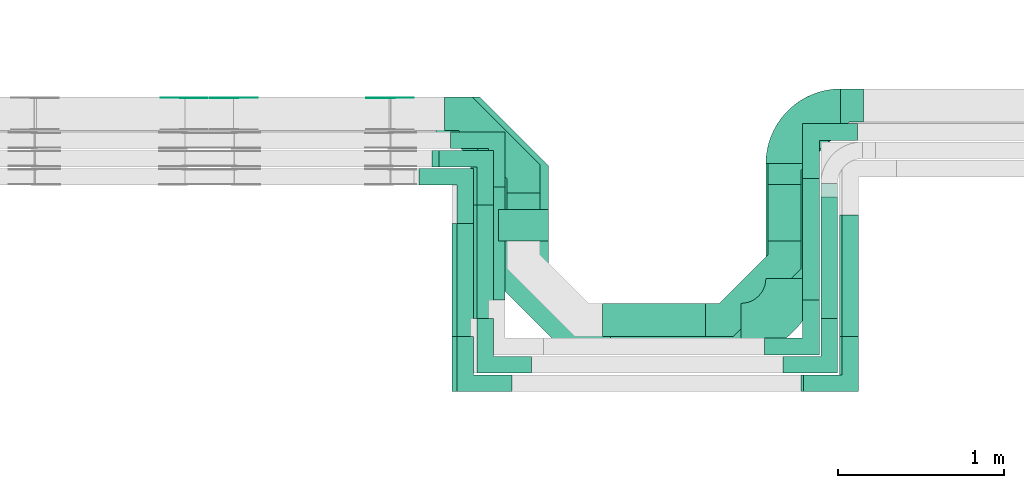
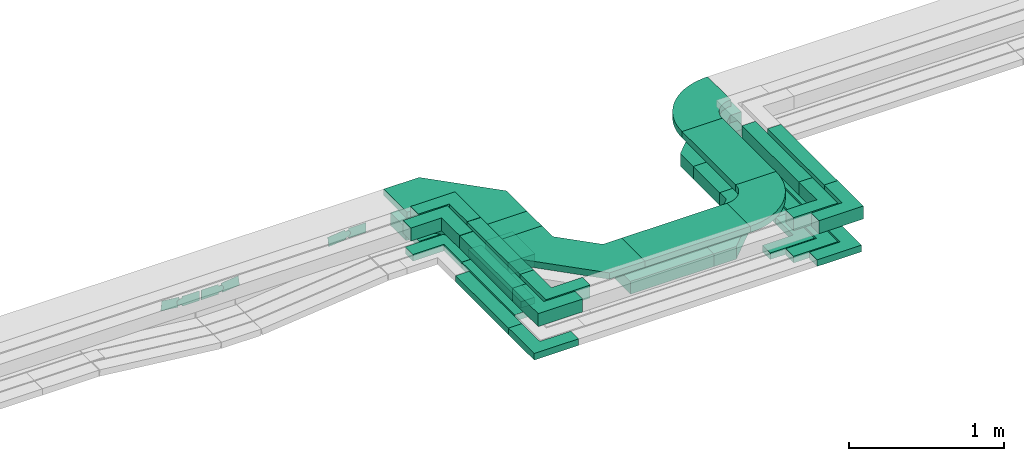
# One storey, part 20 of 33: 26 flow fittings, 16 flow segments.
"""IFC2X3 building model written with IfcOpenShell, lengths in millimetres."""

from ifc_helpers import new_model, entity, si_unit, converted_unit, derived_unit, direction, frame, frame_2d, origin, origin_2d_with_axis, place, context, subcontext, project, spatial, polyline, circle_curve, parameter, trimmed, segment, composite_curve, rectangle, outline, extrude, source, transform, mapped, material, type_object, type_shapes, element, save


model = new_model("IFC2X3")

# Units and contexts
model_context = context("Model", 3, precision=0.01, world=origin(), true_north=direction((6.12303176911189e-17, 1.0)))
body_context = subcontext(model_context, "Body", "Model", "MODEL_VIEW")
ifc_project = project(units=[si_unit("LENGTHUNIT", "METRE", prefix="MILLI"), si_unit("AREAUNIT", "SQUARE_METRE"), si_unit("VOLUMEUNIT", "CUBIC_METRE"), converted_unit("PLANEANGLEUNIT", "DEGREE", entity("IfcRatioMeasure", 0.0174532925199433), si_unit("PLANEANGLEUNIT", "RADIAN"), dimensions=[0, 0, 0, 0, 0, 0, 0]), si_unit("MASSUNIT", "GRAM", prefix="KILO"), derived_unit("MASSDENSITYUNIT", [(si_unit("MASSUNIT", "GRAM", prefix="KILO"), 1), (si_unit("LENGTHUNIT", "METRE"), -3)]), derived_unit("MOMENTOFINERTIAUNIT", [(si_unit("LENGTHUNIT", "METRE"), 4)]), si_unit("TIMEUNIT", "SECOND"), si_unit("FREQUENCYUNIT", "HERTZ"), si_unit("THERMODYNAMICTEMPERATUREUNIT", "DEGREE_CELSIUS"), derived_unit("THERMALTRANSMITTANCEUNIT", [(si_unit("MASSUNIT", "GRAM", prefix="KILO"), 1), (si_unit("THERMODYNAMICTEMPERATUREUNIT", "KELVIN"), -1), (si_unit("TIMEUNIT", "SECOND"), -3)]), derived_unit("VOLUMETRICFLOWRATEUNIT", [(si_unit("LENGTHUNIT", "METRE"), 3), (si_unit("TIMEUNIT", "SECOND"), -1)]), derived_unit("MASSFLOWRATEUNIT", [(si_unit("MASSUNIT", "GRAM", prefix="KILO"), 1), (si_unit("TIMEUNIT", "SECOND"), -1)]), derived_unit("ROTATIONALFREQUENCYUNIT", [(si_unit("TIMEUNIT", "SECOND"), -1)]), si_unit("ELECTRICCURRENTUNIT", "AMPERE"), si_unit("ELECTRICVOLTAGEUNIT", "VOLT"), si_unit("POWERUNIT", "WATT"), si_unit("FORCEUNIT", "NEWTON", prefix="KILO"), si_unit("ILLUMINANCEUNIT", "LUX"), si_unit("LUMINOUSFLUXUNIT", "LUMEN"), si_unit("LUMINOUSINTENSITYUNIT", "CANDELA"), derived_unit("USERDEFINED", [(si_unit("MASSUNIT", "GRAM", prefix="KILO"), -1), (si_unit("LENGTHUNIT", "METRE"), -2), (si_unit("TIMEUNIT", "SECOND"), 3), (si_unit("LUMINOUSFLUXUNIT", "LUMEN"), 1)]), derived_unit("LINEARVELOCITYUNIT", [(si_unit("LENGTHUNIT", "METRE"), 1), (si_unit("TIMEUNIT", "SECOND"), -1)]), si_unit("PRESSUREUNIT", "PASCAL"), derived_unit("USERDEFINED", [(si_unit("LENGTHUNIT", "METRE"), -2), (si_unit("MASSUNIT", "GRAM", prefix="KILO"), 1), (si_unit("TIMEUNIT", "SECOND"), -2)]), derived_unit("LINEARFORCEUNIT", [(si_unit("MASSUNIT", "GRAM", prefix="KILO"), 1), (si_unit("LENGTHUNIT", "METRE"), 1), (si_unit("TIMEUNIT", "SECOND"), -2), (si_unit("LENGTHUNIT", "METRE"), -1)]), derived_unit("PLANARFORCEUNIT", [(si_unit("MASSUNIT", "GRAM", prefix="KILO"), 1), (si_unit("LENGTHUNIT", "METRE"), 1), (si_unit("TIMEUNIT", "SECOND"), -2), (si_unit("LENGTHUNIT", "METRE"), -2)])], contexts=[model_context])

# Site, building, storey
site_placement = place(None, frame((0.0, -0.00077364408347762, 0.0)))
site = spatial("IfcSite", under=ifc_project, at=site_placement, CompositionType="ELEMENT")
building_placement = place(site_placement, origin())
building = spatial("IfcBuilding", under=site, at=building_placement, CompositionType="ELEMENT")
storey_placement = place(building_placement, frame((0.0, 0.0, 8100.0)))
storey = spatial("IfcBuildingStorey", under=building, at=storey_placement, CompositionType="ELEMENT", Elevation=8100.0)

# Flow segments
cable_carrier_segment_type = type_object("IfcCableCarrierSegmentType", PredefinedType="CABLETRAYSEGMENT")
flow_segment_1_placement = place(storey_placement, frame((42997.1884624457, 9308.68960275249, 2547.39498136109)))
element("IfcFlowSegment", 1, at=flow_segment_1_placement, inside=storey, type_object=cable_carrier_segment_type, context=body_context, shape_type="SweptSolid", body=[
    extrude(rectangle(XDim=290.308950714313, YDim=200.000000000007, at=frame_2d((-5.40012479177676e-13, 4.33431068813661e-12), x_axis=(1.0, 0.0))), frame((100.0, 145.154475357158, 0.0), z_axis=(0.0, 0.0, 1.0), x_axis=(0.0, -1.0, 0.0)), (0.0, 0.0, 1.0), 99.9999999999989),
])
flow_segment_2_placement = place(storey_placement, frame((42887.1884624458, 8952.68960275249, 2544.92549664435)))
element("IfcFlowSegment", 2, at=flow_segment_2_placement, inside=storey, type_object=cable_carrier_segment_type, context=body_context, shape_type="SweptSolid", body=[
    extrude(rectangle(XDim=682.308950714327, YDim=99.9999999999946, at=frame_2d((0.0, 4.33075797445781e-12), x_axis=(1.0, 0.0))), frame((50.0, 341.154475357164, 0.0), z_axis=(0.0, 0.0, 1.0), x_axis=(0.0, -1.0, 0.0)), (0.0, 0.0, 1.0), 50.0000000000016),
])
flow_segment_3_placement = place(storey_placement, frame((42777.1884624458, 8842.6896027525, 2546.31908538351)))
element("IfcFlowSegment", 3, at=flow_segment_3_placement, inside=storey, type_object=cable_carrier_segment_type, context=body_context, shape_type="SweptSolid", body=[
    extrude(rectangle(XDim=682.308950714317, YDim=99.9999999999946, at=frame_2d((0.0, 4.33075797445781e-12), x_axis=(1.0, 0.0))), frame((50.0, 341.154475357159, 0.0), z_axis=(0.0, 0.0, 1.0), x_axis=(0.0, -1.0, 0.0)), (0.0, 0.0, 1.0), 49.9999999999995),
])
flow_segment_4_placement = place(storey_placement, frame((42667.1884624458, 8732.69104941504, 2546.66940793271)))
element("IfcFlowSegment", 4, at=flow_segment_4_placement, inside=storey, type_object=cable_carrier_segment_type, context=body_context, shape_type="SweptSolid", body=[
    extrude(rectangle(XDim=682.307504051767, YDim=99.9999999999946, at=origin_2d_with_axis()), frame((50.0, 341.153752025884, 0.0), z_axis=(0.0, 0.0, 1.0), x_axis=(0.0, -1.0, 0.0)), (0.0, 0.0, 1.0), 50.0000000000016),
])
flow_segment_5_placement = place(storey_placement, frame((42697.1884624458, 8732.69104941503, 2799.2813532093)))
element("IfcFlowSegment", 5, at=flow_segment_5_placement, inside=storey, type_object=cable_carrier_segment_type, context=body_context, shape_type="SweptSolid", body=[
    extrude(rectangle(XDim=682.307504051765, YDim=99.9999999999946, at=frame_2d((-1.08002495835535e-12, 0.0), x_axis=(1.0, 0.0))), frame((50.0, 341.153752025881, 0.0), z_axis=(0.0, 0.0, 1.0), x_axis=(0.0, -1.0, 0.0)), (0.0, 0.0, 1.0), 99.9999999999989),
])
flow_segment_6_placement = place(storey_placement, frame((42817.1884624458, 8842.68960275249, 2800.01096864734)))
element("IfcFlowSegment", 6, at=flow_segment_6_placement, inside=storey, type_object=cable_carrier_segment_type, context=body_context, shape_type="SweptSolid", body=[
    extrude(rectangle(XDim=682.308950714305, YDim=99.9999999999946, at=frame_2d((0.0, 4.33075797445781e-12), x_axis=(1.0, 0.0))), frame((50.0, 341.154475357153, 0.0), z_axis=(0.0, 0.0, 1.0), x_axis=(0.0, -1.0, 0.0)), (0.0, 0.0, 1.0), 99.9999999999989),
])
flow_segment_7_placement = place(storey_placement, frame((42947.1884624458, 9308.68960275249, 2800.01711339306)))
element("IfcFlowSegment", 7, at=flow_segment_7_placement, inside=storey, type_object=cable_carrier_segment_type, context=body_context, shape_type="SweptSolid", body=[
    extrude(rectangle(XDim=190.308950714306, YDim=300.000000000001, at=origin_2d_with_axis()), frame((150.0, 95.154475357153, 0.0), z_axis=(0.0, 0.0, 1.0), x_axis=(0.0, -1.0, 0.0)), (0.0, 0.0, 1.0), 50.0000000000016),
])
flow_segment_8_placement = place(storey_placement, frame((43573.1884624458, 8732.68960275249, 2547.39498136109)))
element("IfcFlowSegment", 8, at=flow_segment_8_placement, inside=storey, type_object=cable_carrier_segment_type, context=body_context, shape_type="SweptSolid", body=[
    extrude(rectangle(XDim=620.201042721613, YDim=200.0, at=frame_2d((4.32009983342141e-12, 1.08713038571295e-12), x_axis=(1.0, 0.0))), frame((310.100521360802, 100.0, 0.0)), (0.0, 0.0, 1.0), 99.9999999999989),
])
flow_segment_9_placement = place(storey_placement, frame((44557.7215031972, 9083.68960275249, 2800.01711339307)))
element("IfcFlowSegment", 9, at=flow_segment_9_placement, inside=storey, type_object=cable_carrier_segment_type, context=body_context, shape_type="SweptSolid", body=[
    extrude(rectangle(XDim=690.309773162948, YDim=300.000000000001, at=origin_2d_with_axis()), frame((150.0, 345.154886581474, 0.0), z_axis=(0.0, 0.0, 1.0), x_axis=(0.0, -1.0, 0.0)), (0.0, 0.0, 1.0), 50.0000000000016),
])
flow_segment_10_placement = place(storey_placement, frame((43623.1884624458, 8632.68960275249, 2800.01711339307)))
element("IfcFlowSegment", 10, at=flow_segment_10_placement, inside=storey, type_object=cable_carrier_segment_type, context=body_context, shape_type="SweptSolid", body=[
    extrude(rectangle(XDim=783.533040751397, YDim=300.000000000001, at=frame_2d((0.0, 5.40012479177676e-13), x_axis=(1.0, 0.0))), frame((391.766520375699, 150.0, 0.0)), (0.0, 0.0, 1.0), 50.0000000000038),
])
flow_segment_11_placement = place(storey_placement, frame((44889.3895051674, 8842.68960275247, 2800.01096864734)))
element("IfcFlowSegment", 11, at=flow_segment_11_placement, inside=storey, type_object=cable_carrier_segment_type, context=body_context, shape_type="SweptSolid", body=[
    extrude(rectangle(XDim=732.309773162997, YDim=99.9999999999946, at=frame_2d((5.6843418860808e-13, 4.33075797445781e-12), x_axis=(1.0, 0.0))), frame((50.0, 366.154886581501, 0.0), z_axis=(0.0, 0.0, 1.0), x_axis=(0.0, -1.0, 0.0)), (0.0, 0.0, 1.0), 99.9999999999968),
])
flow_segment_12_placement = place(storey_placement, frame((45014.8957997884, 8732.69104941501, 2799.28132970995)))
element("IfcFlowSegment", 12, at=flow_segment_12_placement, inside=storey, type_object=cable_carrier_segment_type, context=body_context, shape_type="SweptSolid", body=[
    extrude(rectangle(XDim=732.30962512756, YDim=100.000000000006, at=origin_2d_with_axis()), frame((50.0, 366.154812563782, 2.34993537162609e-05), z_axis=(4.69987074325191e-07, 0.0, 1.0), x_axis=(0.0, -1.0, 0.0)), (0.0, 0.0, 1.0), 100.000000000001),
])
flow_segment_13_placement = place(storey_placement, frame((44569.3895051674, 9308.68960275249, 2547.39498136109)))
element("IfcFlowSegment", 13, at=flow_segment_13_placement, inside=storey, type_object=cable_carrier_segment_type, context=body_context, shape_type="SweptSolid", body=[
    extrude(rectangle(XDim=340.309773162912, YDim=200.000000000007, at=frame_2d((5.54223333892878e-13, 0.0), x_axis=(1.0, 0.0))), frame((100.0, 170.154886581454, 0.0), z_axis=(0.0, 0.0, 1.0), x_axis=(0.0, 1.0, 0.0)), (0.0, 0.0, 1.0), 99.9999999999989),
])
flow_segment_14_placement = place(storey_placement, frame((44779.3895051674, 8952.68960275247, 2544.92549664435)))
element("IfcFlowSegment", 14, at=flow_segment_14_placement, inside=storey, type_object=cable_carrier_segment_type, context=body_context, shape_type="SweptSolid", body=[
    extrude(rectangle(XDim=732.309773162961, YDim=99.9999999999946, at=origin_2d_with_axis()), frame((50.0, 366.154886581483, 0.0), z_axis=(0.0, 0.0, 1.0), x_axis=(0.0, 1.0, 0.0)), (0.0, 0.0, 1.0), 50.0000000000016),
])
flow_segment_15_placement = place(storey_placement, frame((44889.3895051673, 8842.68960275247, 2546.31908538351)))
element("IfcFlowSegment", 15, at=flow_segment_15_placement, inside=storey, type_object=cable_carrier_segment_type, context=body_context, shape_type="SweptSolid", body=[
    extrude(rectangle(XDim=811.309773162958, YDim=99.9999999999946, at=frame_2d((5.40012479177676e-13, 0.0), x_axis=(1.0, 0.0))), frame((50.0, 405.65488658148, 0.0), z_axis=(0.0, 0.0, 1.0), x_axis=(0.0, 1.0, 0.0)), (0.0, 0.0, 1.0), 50.0000000000016),
])
flow_segment_16_placement = place(storey_placement, frame((44999.8958236255, 8732.69104941501, 2546.66940793271)))
element("IfcFlowSegment", 16, at=flow_segment_16_placement, inside=storey, type_object=cable_carrier_segment_type, context=body_context, shape_type="SweptSolid", body=[
    extrude(rectangle(XDim=732.309800463485, YDim=99.9999999999946, at=frame_2d((-5.40012479177676e-13, 0.0), x_axis=(1.0, 0.0))), frame((50.0, 366.154900231747, 0.0), z_axis=(0.0, 0.0, 1.0), x_axis=(0.0, 1.0, 0.0)), (0.0, 0.0, 1.0), 50.0000000000016),
])

# Flow fittings
ifc_material_1 = material()
cable_carrier_fitting_type_1 = type_object("IfcCableCarrierFittingType", Name="470_DKC_G5_Sheet horizontal bend:-", PredefinedType="NOTDEFINED", material=ifc_material_1)
shared_shape_1 = source(origin(), body_context, "Body", "SweptSolid", [
    extrude(outline(polyline([(-269.5, -306.499999999999), (-102.07864376269, -306.499999999999), (306.499999999999, 102.07864376269), (306.5, 269.499999999999), (106.5, 269.499999999999), (106.5, 184.921356237309), (-184.921356237309, -106.499999999999), (-269.5, -106.499999999999), (-269.5, -306.499999999999)])), frame((-206.499999999993, 206.499999999989, -50.0)), (0.0, 0.0, 1.0), 100.0),
])
type_shapes(cable_carrier_fitting_type_1, [shared_shape_1])
flow_fitting_1_placement = place(storey_placement, frame((44669.3895051674, 8832.68960275251, 2597.39498136109)))
element("IfcFlowFitting", 17, at=flow_fitting_1_placement, inside=storey, type_object=cable_carrier_fitting_type_1, material=ifc_material_1, Name="470_DKC_G5_Sheet horizontal bend:-", ObjectType="470_DKC_G5_Sheet horizontal bend:-", context=body_context, shape_type="MappedRepresentation", body=[
    mapped(shared_shape_1, transform((0.0, 0.0, 0.0), scale=1.0)),
])
for number, where, z_axis, x_axis, name in (
    (18, (44669.3895051674, 10124.9993759154, 2597.39498136109), (0.0, 0.0, 1.0), (-1.0, 0.0, 0.0), "470_DKC_G5_Sheet horizontal bend:-"),
    (19, (43097.1884624458, 10074.9985534668, 2597.39498136109), (0.0, 0.0, 1.0), (0.0, 1.0, 0.0), "470_DKC_G5_Sheet horizontal bend:-"),
):
    element("IfcFlowFitting", number, at=place(storey_placement, frame(where, z_axis=z_axis, x_axis=x_axis)), inside=storey, type_object=cable_carrier_fitting_type_1, material=ifc_material_1, Name=name, ObjectType="470_DKC_G5_Sheet horizontal bend:-", context=body_context, shape_type="MappedRepresentation", body=[
        mapped(shared_shape_1, transform((0.0, 0.0, 0.0), scale=1.0)),
    ])
cable_carrier_fitting_type_2 = type_object("IfcCableCarrierFittingType", Name="470_DKC_F5_Mesh horizontal angle:At right angles", PredefinedType="NOTDEFINED", material=ifc_material_1)
shared_shape_2 = source(origin(), body_context, "Body", "SweptSolid", [
    extrude(outline(polyline([(-143.333333333335, -143.333333333332), (186.666666666646, -143.333333333332), (186.666666666652, -43.3333333333317), (-43.3333333333294, -43.3333333333373), (-43.3333333333166, 186.666666666663), (-143.333333333317, 186.666666666669), (-143.333333333335, -143.333333333332)])), frame((-93.3333333333341, 93.3333333333192, -25.0), z_axis=(0.0, 0.0, 1.0), x_axis=(0.0, 1.0, 0.0)), (0.0, 0.0, 1.0), 51.9999999999999),
])
type_shapes(cable_carrier_fitting_type_2, [shared_shape_2])
flow_fitting_2_placement = place(storey_placement, frame((42717.1884624458, 8452.69104941505, 2571.66940793271), z_axis=(0.0, 0.0, 1.0), x_axis=(0.0, -1.0, 0.0)))
element("IfcFlowFitting", 20, at=flow_fitting_2_placement, inside=storey, type_object=cable_carrier_fitting_type_2, material=ifc_material_1, Name="470_DKC_F5_Mesh horizontal angle:At right angles", ObjectType="470_DKC_F5_Mesh horizontal angle:At right angles", context=body_context, shape_type="MappedRepresentation", body=[
    mapped(shared_shape_2, transform((0.0, 0.0, 0.0), scale=1.0)),
])
flow_fitting_3_placement = place(storey_placement, frame((44829.3895051674, 8672.68960275251, 2569.92549664435)))
element("IfcFlowFitting", 21, at=flow_fitting_3_placement, inside=storey, type_object=cable_carrier_fitting_type_2, material=ifc_material_1, Name="470_DKC_F5_Mesh horizontal angle:At right angles", ObjectType="470_DKC_F5_Mesh horizontal angle:At right angles", context=body_context, shape_type="MappedRepresentation", body=[
    mapped(shared_shape_2, transform((0.0, 0.0, 0.0), scale=1.0)),
])
flow_fitting_4_placement = place(storey_placement, frame((44829.3895051674, 9964.9993759154, 2569.92549664435), z_axis=(0.0, 0.0, 1.0), x_axis=(-1.0, 0.0, 0.0)))
element("IfcFlowFitting", 22, at=flow_fitting_4_placement, inside=storey, type_object=cable_carrier_fitting_type_2, material=ifc_material_1, Name="470_DKC_F5_Mesh horizontal angle:At right angles", ObjectType="470_DKC_F5_Mesh horizontal angle:At right angles", context=body_context, shape_type="MappedRepresentation", body=[
    mapped(shared_shape_2, transform((0.0, 0.0, 0.0), scale=1.0)),
])
for number, where, name in (
    (23, (45049.8958236255, 8452.69104941505, 2571.66940793271), "470_DKC_F5_Mesh horizontal angle:At right angles"),
    (24, (44939.3895051673, 8562.68960275251, 2571.31908538351), "470_DKC_F5_Mesh horizontal angle:At right angles"),
):
    element("IfcFlowFitting", number, at=place(storey_placement, frame(where)), inside=storey, type_object=cable_carrier_fitting_type_2, material=ifc_material_1, Name=name, ObjectType="470_DKC_F5_Mesh horizontal angle:At right angles", context=body_context, shape_type="MappedRepresentation", body=[
        mapped(shared_shape_2, transform((0.0, 0.0, 0.0), scale=1.0)),
    ])
for number, where, z_axis, x_axis, name in (
    (25, (42827.1884624458, 9804.9985534668, 2571.31908538351), (0.0, 0.0, 1.0), (0.0, 1.0, 0.0), "470_DKC_F5_Mesh horizontal angle:At right angles"),
    (26, (42937.1884624458, 9914.99855346681, 2569.92549664435), (0.00011888167183542, 0.0, 0.999999992933574), (0.0, 1.0, 0.0), "470_DKC_F5_Mesh horizontal angle:At right angles"),
):
    element("IfcFlowFitting", number, at=place(storey_placement, frame(where, z_axis=z_axis, x_axis=x_axis)), inside=storey, type_object=cable_carrier_fitting_type_2, material=ifc_material_1, Name=name, ObjectType="470_DKC_F5_Mesh horizontal angle:At right angles", context=body_context, shape_type="MappedRepresentation", body=[
        mapped(shared_shape_2, transform((0.0, 0.0, 0.0), scale=1.0)),
    ])
cable_carrier_fitting_type_3 = type_object("IfcCableCarrierFittingType", Name="470_DKC_F5_Mesh horizontal angle:At right angles", PredefinedType="NOTDEFINED", material=ifc_material_1)
shared_shape_3 = source(origin(), body_context, "Body", "SweptSolid", [
    extrude(outline(polyline([(-143.333333333335, -143.333333333332), (186.666666666646, -143.333333333332), (186.666666666652, -43.3333333333317), (-43.3333333333294, -43.3333333333373), (-43.3333333333166, 186.666666666663), (-143.333333333317, 186.666666666669), (-143.333333333335, -143.333333333332)])), frame((-93.3333333333341, 93.3333333333192, -50.0), z_axis=(0.0, 0.0, 1.0), x_axis=(0.0, 1.0, 0.0)), (0.0, 0.0, 1.0), 102.0),
])
type_shapes(cable_carrier_fitting_type_3, [shared_shape_3])
for number, where, z_axis, x_axis, name in (
    (27, (42747.1884624458, 8452.69104941504, 2849.2813532093), (0.0, 0.0, 1.0), (0.0, -1.0, 0.0), "470_DKC_F5_Mesh horizontal angle:At right angles"),
    (28, (42867.1884624458, 8562.6896027525, 2850.01096864734), (0.0, 0.0, 1.0), (0.0, -1.0, 0.0), "470_DKC_F5_Mesh horizontal angle:At right angles"),
):
    element("IfcFlowFitting", number, at=place(storey_placement, frame(where, z_axis=z_axis, x_axis=x_axis)), inside=storey, type_object=cable_carrier_fitting_type_3, material=ifc_material_1, Name=name, ObjectType="470_DKC_F5_Mesh horizontal angle:At right angles", context=body_context, shape_type="MappedRepresentation", body=[
        mapped(shared_shape_3, transform((0.0, 0.0, 0.0), scale=1.0)),
    ])
for number, where, name in (
    (29, (44939.3895051673, 8562.68960275251, 2850.01096864734), "470_DKC_F5_Mesh horizontal angle:At right angles"),
    (30, (45064.8958232877, 8452.69104941505, 2849.2813532093), "470_DKC_F5_Mesh horizontal angle:At right angles"),
):
    element("IfcFlowFitting", number, at=place(storey_placement, frame(where)), inside=storey, type_object=cable_carrier_fitting_type_3, material=ifc_material_1, Name=name, ObjectType="470_DKC_F5_Mesh horizontal angle:At right angles", context=body_context, shape_type="MappedRepresentation", body=[
        mapped(shared_shape_3, transform((0.0, 0.0, 0.0), scale=1.0)),
    ])
for number, where, z_axis, x_axis, name in (
    (31, (42747.1884624458, 9694.99855346678, 2849.2813532093), (0.0, 0.0, 1.0), (0.0, 1.0, 0.0), "470_DKC_F5_Mesh horizontal angle:At right angles"),
    (32, (42867.1884624458, 9804.99855346678, 2850.01096864734), (0.0, 0.0, 1.0), (0.0, 1.0, 0.0), "470_DKC_F5_Mesh horizontal angle:At right angles"),
):
    element("IfcFlowFitting", number, at=place(storey_placement, frame(where, z_axis=z_axis, x_axis=x_axis)), inside=storey, type_object=cable_carrier_fitting_type_3, material=ifc_material_1, Name=name, ObjectType="470_DKC_F5_Mesh horizontal angle:At right angles", context=body_context, shape_type="MappedRepresentation", body=[
        mapped(shared_shape_3, transform((0.0, 0.0, 0.0), scale=1.0)),
    ])
cable_carrier_fitting_type_4 = type_object("IfcCableCarrierFittingType", Name="470_DKC_G5_Sheet horizontal bend:-", PredefinedType="NOTDEFINED", material=ifc_material_1)
shared_shape_4 = source(origin(), body_context, "Body", "SweptSolid", [
    extrude(outline(polyline([(-313.25, -362.749999999999), (-50.1179656440353, -362.749999999999), (362.749999999999, 50.1179656440352), (362.75, 313.249999999999), (62.7500000000001, 313.25), (62.7499999999997, 174.382034355964), (-174.382034355964, -62.7499999999997), (-313.25, -62.7499999999995), (-313.25, -362.749999999999)])), frame((-212.749999999993, 212.749999999989, -25.0)), (0.0, 0.0, 1.0), 50.0000000000003),
])
type_shapes(cable_carrier_fitting_type_4, [shared_shape_4])
for number, where, z_axis, x_axis, name in (
    (33, (43097.1884624457, 10024.9985534668, 2825.01711339307), (0.0, 0.0, 1.0), (0.0, 1.0, 0.0), "470_DKC_G5_Sheet horizontal bend:-"),
    (34, (43097.1884624458, 8782.6896027525, 2825.01711339307), (0.0, 0.0, 1.0), (0.0, -1.0, 0.0), "470_DKC_G5_Sheet horizontal bend:-"),
):
    element("IfcFlowFitting", number, at=place(storey_placement, frame(where, z_axis=z_axis, x_axis=x_axis)), inside=storey, type_object=cable_carrier_fitting_type_4, material=ifc_material_1, Name=name, ObjectType="470_DKC_G5_Sheet horizontal bend:-", context=body_context, shape_type="MappedRepresentation", body=[
        mapped(shared_shape_4, transform((0.0, 0.0, 0.0), scale=1.0)),
    ])
cable_carrier_fitting_type_5 = type_object("IfcCableCarrierFittingType", Name="470_DKC_S5_Variable Angle Elbow 0-45:-", PredefinedType="NOTDEFINED", material=ifc_material_1)
shared_shape_5 = source(origin(), body_context, "Body", "SweptSolid", [
    extrude(outline(composite_curve([segment(polyline([(-150.749999999996, -300.250000000003), (-149.749999999994, -300.250000000003)]), True, "CONTINUOUS"), segment(trimmed(circle_curve(frame_2d((-149.750000000002, 149.749999999997), x_axis=(0.0, -1.0)), 450.0), [parameter(0.0)], [parameter(90.0000000000001)], True, "PARAMETER"), True, "CONTINUOUS"), segment(polyline([(300.249999999997, 149.750000000005), (300.249999999997, 150.750000000004)]), True, "CONTINUOUS"), segment(polyline([(300.249999999997, 150.750000000003), (0.249999999997449, 150.750000000002)]), True, "CONTINUOUS"), segment(polyline([(0.249999999997449, 150.750000000002), (0.249999999997438, 149.75)]), True, "CONTINUOUS"), segment(trimmed(circle_curve(frame_2d((-149.750000000002, 149.749999999997), x_axis=(0.0, -1.0)), 150.0), [parameter(0.0)], [parameter(90.0000000000001)], True, "PARAMETER"), False, "CONTINUOUS"), segment(polyline([(-149.749999999999, -0.250000000002818), (-150.750000000001, -0.250000000002835)]), True, "CONTINUOUS"), segment(polyline([(-150.750000000001, -0.250000000002835), (-150.749999999996, -300.250000000003)]), True, "CONTINUOUS")], self_intersect=False)), frame((-150.249999999991, 150.249999999992, -25.0)), (0.0, 0.0, 1.0), 49.9999999999974),
])
type_shapes(cable_carrier_fitting_type_5, [shared_shape_5])
flow_fitting_5_placement = place(storey_placement, frame((44707.7215031971, 8782.68960275251, 2825.01711339307)))
element("IfcFlowFitting", 35, at=flow_fitting_5_placement, inside=storey, type_object=cable_carrier_fitting_type_5, material=ifc_material_1, Name="470_DKC_S5_Variable Angle Elbow 0-45:-", ObjectType="470_DKC_S5_Variable Angle Elbow 0-45:-", context=body_context, shape_type="MappedRepresentation", body=[
    mapped(shared_shape_5, transform((0.0, 0.0, 0.0), scale=1.0)),
])
flow_fitting_6_placement = place(storey_placement, frame((44707.7215031972, 10074.9993759154, 2825.01711339307), z_axis=(0.00105535618082575, 0.0, 0.999999443111511), x_axis=(-0.999999443111511, 0.0, 0.00105535618082575)))
element("IfcFlowFitting", 36, at=flow_fitting_6_placement, inside=storey, type_object=cable_carrier_fitting_type_5, material=ifc_material_1, Name="470_DKC_S5_Variable Angle Elbow 0-45:-", ObjectType="470_DKC_S5_Variable Angle Elbow 0-45:-", context=body_context, shape_type="MappedRepresentation", body=[
    mapped(shared_shape_5, transform((0.0, 0.0, 0.0), scale=1.0)),
])
ifc_material_2 = material(Name="G")
cable_carrier_fitting_type_6 = type_object("IfcCableCarrierFittingType", PredefinedType="NOTDEFINED", material=ifc_material_2)
shared_shape_6 = source(origin(), body_context, "Body", "SweptSolid", [
    extrude(outline(composite_curve([segment(trimmed(circle_curve(frame_2d((-41.4651162790697, 0.0), x_axis=(1.0, 0.0)), 25.0), [parameter(90.0000000000007)], [parameter(270.0)], True, "PARAMETER"), True, "CONTINUOUS"), segment(polyline([(-41.4651162790697, -25.0), (-29.9651162790697, -25.0)]), True, "CONTINUOUS"), segment(polyline([(-29.9651162790697, -25.0), (-28.1046511627907, -38.5)]), True, "CONTINUOUS"), segment(polyline([(-28.1046511627907, -38.5), (99.5348837209303, -38.5)]), True, "CONTINUOUS"), segment(polyline([(99.5348837209303, -38.5), (99.5348837209303, 38.5)]), True, "CONTINUOUS"), segment(polyline([(99.5348837209303, 38.5), (-28.1046511627907, 38.5)]), True, "CONTINUOUS"), segment(polyline([(-28.1046511627907, 38.5), (-29.9651162790697, 25.0)]), True, "CONTINUOUS"), segment(polyline([(-29.9651162790697, 25.0), (-41.46511627907, 25.0)]), True, "CONTINUOUS")], self_intersect=False)), frame((41.4651162790697, 0.0, 0.0), z_axis=(0.0, 0.0, -1.0), x_axis=(1.0, 0.0, 0.0)), (0.0, 0.0, -1.0), 2.0),
])
type_shapes(cable_carrier_fitting_type_6, [shared_shape_6])
for number, where, z_axis, x_axis in (
    (37, (41055.8126494717, 10170.458553477, 2497.10630735315), (0.0, 1.0, 0.0), (-0.993961132894515, 0.0, 0.10973270385374)),
    (38, (42295.8624164839, 10170.458553477, 2597.39498136111), (0.0, 1.0, 0.0), (1.0, 0.0, 0.0)),
):
    element("IfcFlowFitting", number, at=place(storey_placement, frame(where, z_axis=z_axis, x_axis=x_axis)), inside=storey, type_object=cable_carrier_fitting_type_6, material=ifc_material_2, context=body_context, shape_type="MappedRepresentation", body=[
        mapped(shared_shape_6, transform((0.0, 0.0, 0.0), scale=1.0)),
    ])
cable_carrier_fitting_type_7 = type_object("IfcCableCarrierFittingType", PredefinedType="NOTDEFINED", material=ifc_material_2)
shared_shape_7 = source(origin(), body_context, "Body", "SweptSolid", [
    extrude(outline(composite_curve([segment(trimmed(circle_curve(frame_2d((-41.4651162790697, 0.0), x_axis=(1.0, 0.0)), 25.0), [parameter(90.0000000000007)], [parameter(270.0)], True, "PARAMETER"), True, "CONTINUOUS"), segment(polyline([(-41.4651162790697, -25.0), (-29.9651162790697, -25.0)]), True, "CONTINUOUS"), segment(polyline([(-29.9651162790697, -25.0), (-28.1046511627907, -38.5)]), True, "CONTINUOUS"), segment(polyline([(-28.1046511627907, -38.5), (99.5348837209303, -38.5)]), True, "CONTINUOUS"), segment(polyline([(99.5348837209303, -38.5), (99.5348837209303, 38.5)]), True, "CONTINUOUS"), segment(polyline([(99.5348837209303, 38.5), (-28.1046511627907, 38.5)]), True, "CONTINUOUS"), segment(polyline([(-28.1046511627907, 38.5), (-29.9651162790697, 25.0)]), True, "CONTINUOUS"), segment(polyline([(-29.9651162790697, 25.0), (-41.46511627907, 25.0)]), True, "CONTINUOUS")], self_intersect=False)), frame((41.4651162790697, 0.0, 0.0)), (0.0, 0.0, 1.0), 2.0),
])
type_shapes(cable_carrier_fitting_type_7, [shared_shape_7])
flow_fitting_7_placement = place(storey_placement, frame((41353.14888081, 10170.458553477, 2497.10630735315), z_axis=(0.0, 1.0, 0.0), x_axis=(0.994388913179106, 0.0, 0.105786054593584)))
element("IfcFlowFitting", 39, at=flow_fitting_7_placement, inside=storey, type_object=cable_carrier_fitting_type_7, material=ifc_material_2, context=body_context, shape_type="MappedRepresentation", body=[
    mapped(shared_shape_7, transform((0.0, 0.0, 0.0), scale=1.0)),
])
cable_carrier_fitting_type_8 = type_object("IfcCableCarrierFittingType", PredefinedType="NOTDEFINED", material=ifc_material_2)
shared_shape_8 = source(origin(), body_context, "Body", "SweptSolid", [
    extrude(outline(composite_curve([segment(trimmed(circle_curve(frame_2d((-41.4651162790697, 0.0), x_axis=(1.0, 0.0)), 25.0), [parameter(90.0000000000007)], [parameter(270.0)], True, "PARAMETER"), True, "CONTINUOUS"), segment(polyline([(-41.4651162790697, -25.0), (-29.9651162790697, -25.0)]), True, "CONTINUOUS"), segment(polyline([(-29.9651162790697, -25.0), (-28.1046511627907, -38.5)]), True, "CONTINUOUS"), segment(polyline([(-28.1046511627907, -38.5), (99.5348837209303, -38.5)]), True, "CONTINUOUS"), segment(polyline([(99.5348837209303, -38.5), (99.5348837209303, 38.5)]), True, "CONTINUOUS"), segment(polyline([(99.5348837209303, 38.5), (-28.1046511627907, 38.5)]), True, "CONTINUOUS"), segment(polyline([(-28.1046511627907, 38.5), (-29.9651162790697, 25.0)]), True, "CONTINUOUS"), segment(polyline([(-29.9651162790697, 25.0), (-41.46511627907, 25.0)]), True, "CONTINUOUS")], self_intersect=False)), frame((41.4651162790697, 0.0, 0.0), z_axis=(0.0, 0.0, -1.0), x_axis=(1.0, 0.0, 0.0)), (0.0, 0.0, -1.0), 2.0),
])
type_shapes(cable_carrier_fitting_type_8, [shared_shape_8])
flow_fitting_8_placement = place(storey_placement, frame((41353.14888081, 10168.458553477, 2497.10630735316), z_axis=(0.0, 1.0, 0.0), x_axis=(-1.0, 0.0, 0.0)))
element("IfcFlowFitting", 40, at=flow_fitting_8_placement, inside=storey, type_object=cable_carrier_fitting_type_8, material=ifc_material_2, context=body_context, shape_type="MappedRepresentation", body=[
    mapped(shared_shape_8, transform((0.0, 0.0, 0.0), scale=1.0)),
])
cable_carrier_fitting_type_9 = type_object("IfcCableCarrierFittingType", PredefinedType="NOTDEFINED", material=ifc_material_2)
shared_shape_9 = source(origin(), body_context, "Body", "SweptSolid", [
    extrude(outline(composite_curve([segment(trimmed(circle_curve(frame_2d((-41.4651162790697, 0.0), x_axis=(1.0, 0.0)), 25.0), [parameter(90.0000000000007)], [parameter(270.0)], True, "PARAMETER"), True, "CONTINUOUS"), segment(polyline([(-41.4651162790697, -25.0), (-29.9651162790697, -25.0)]), True, "CONTINUOUS"), segment(polyline([(-29.9651162790697, -25.0), (-28.1046511627907, -38.5)]), True, "CONTINUOUS"), segment(polyline([(-28.1046511627907, -38.5), (99.5348837209303, -38.5)]), True, "CONTINUOUS"), segment(polyline([(99.5348837209303, -38.5), (99.5348837209303, 38.5)]), True, "CONTINUOUS"), segment(polyline([(99.5348837209303, 38.5), (-28.1046511627907, 38.5)]), True, "CONTINUOUS"), segment(polyline([(-28.1046511627907, 38.5), (-29.9651162790697, 25.0)]), True, "CONTINUOUS"), segment(polyline([(-29.9651162790697, 25.0), (-41.46511627907, 25.0)]), True, "CONTINUOUS")], self_intersect=False)), frame((41.4651162790697, 0.0, 0.0)), (0.0, 0.0, 1.0), 2.0),
])
type_shapes(cable_carrier_fitting_type_9, [shared_shape_9])
for number, where, z_axis, x_axis in (
    (41, (41055.8126494717, 10168.458553477, 2497.10630735316), (0.0, 1.0, 0.0), (1.0, 0.0, 0.0)),
    (42, (42295.8624164839, 10168.458553477, 2597.39498136111), (0.0, 1.0, 0.0), (-0.994388913179106, 0.0, -0.105786054593579)),
):
    element("IfcFlowFitting", number, at=place(storey_placement, frame(where, z_axis=z_axis, x_axis=x_axis)), inside=storey, type_object=cable_carrier_fitting_type_9, material=ifc_material_2, context=body_context, shape_type="MappedRepresentation", body=[
        mapped(shared_shape_9, transform((0.0, 0.0, 0.0), scale=1.0)),
    ])

save(model, "model.ifc")
